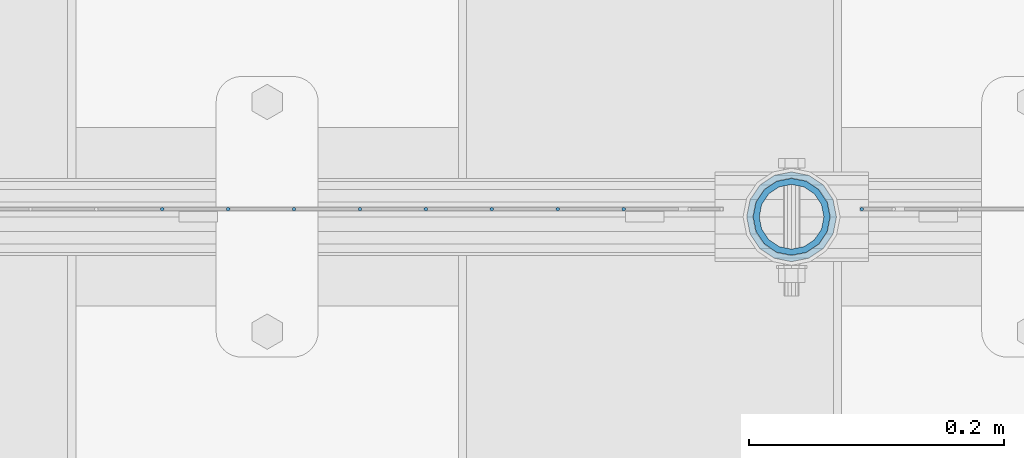
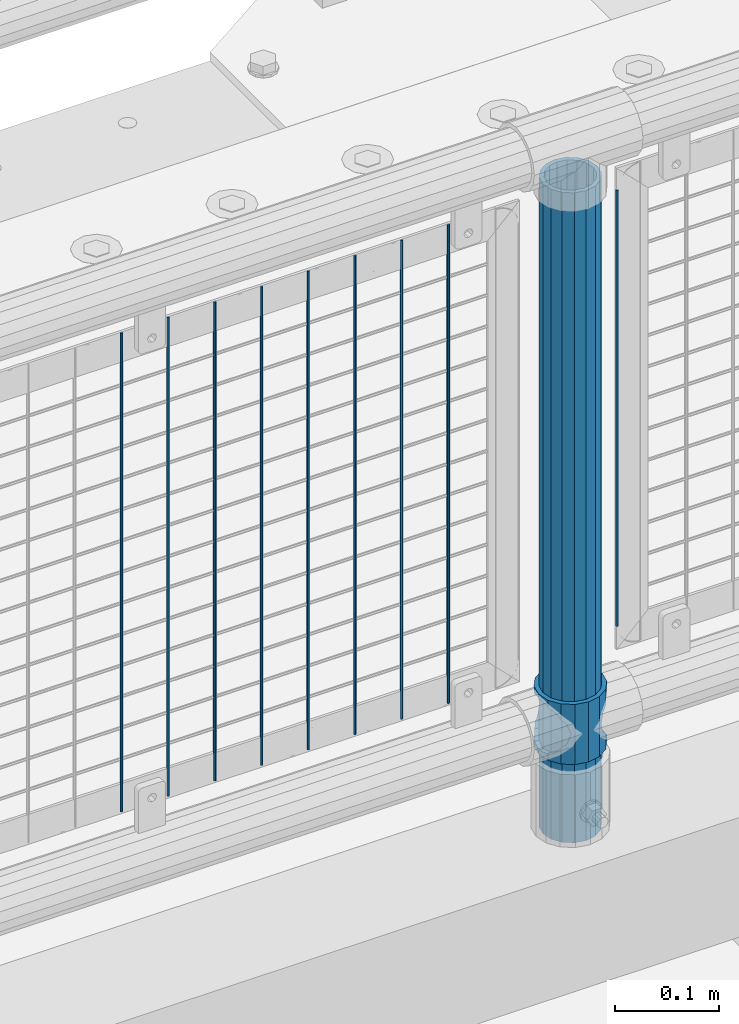
# One storey, part 85 of 240: 11 columns.
"""IFC2X3 building model written with IfcOpenShell, lengths in millimetres."""

from ifc_helpers import new_model, si_unit, frame, origin_with_axes, place, context, subcontext, project, spatial, faceted_brep, material, type_object, element, save


model = new_model("IFC2X3")

# Units and contexts
model_context = context("Model", 3, precision=1e-05, world=origin_with_axes())
body_context = subcontext(model_context, "Body", "Model", "MODEL_VIEW")
ifc_project = project(units=[si_unit("LENGTHUNIT", "METRE", prefix="MILLI"), si_unit("AREAUNIT", "SQUARE_METRE"), si_unit("VOLUMEUNIT", "CUBIC_METRE"), si_unit("MASSUNIT", "GRAM", prefix="KILO"), si_unit("TIMEUNIT", "SECOND"), si_unit("PLANEANGLEUNIT", "RADIAN"), si_unit("SOLIDANGLEUNIT", "STERADIAN"), si_unit("THERMODYNAMICTEMPERATUREUNIT", "DEGREE_CELSIUS"), si_unit("LUMINOUSINTENSITYUNIT", "LUMEN")], contexts=[model_context])

# Site, building, storey
site_placement = place(None, origin_with_axes())
site = spatial("IfcSite", under=ifc_project, at=site_placement, CompositionType="ELEMENT")
building_placement = place(site_placement, origin_with_axes())
building = spatial("IfcBuilding", under=site, at=building_placement, Name="Standard", CompositionType="ELEMENT")
storey_placement = place(building_placement, origin_with_axes())
storey = spatial("IfcBuildingStorey", under=building, at=storey_placement, Name="Undefined", CompositionType="ELEMENT", Elevation=0.0)

# Columns
ifc_material_1 = material(Name="Misc_Undefined")
column_type_1 = type_object("IfcColumnType", PredefinedType="NOTDEFINED")
column_1_placement = place(storey_placement, frame((51361.0, 34664.5, 263.02), z_axis=(-1.0, 0.0, 0.0), x_axis=(0.0, 0.0, 1.0)))
element("IfcColumn", 1, at=column_1_placement, inside=storey, type_object=column_type_1, material=ifc_material_1, context=body_context, shape_type="Brep", body=[
    faceted_brep([(56.6106908090114, 21.4606908090136, -21.4606908090136), (56.6106908090114, 21.4606908090136, -27.1226768591077), (61.9623795176703, 13.4513226476338, -32.4743655677739), (63.1897438117172, 11.6144421722784, -32.8397438117172), (63.1897438117172, 11.6144421722784, -28.0397438117143), (46.7644421722801, 28.0397438117143, -11.6144421722784), (46.7644421722801, 28.0397438117143, -20.0882031229849), (51.5310424079941, 24.8548033587067, -24.8548033587067), (35.1500000000015, 30.35, 0.0), (35.1499999999996, 30.3499999999985, -16.6306603983685), (23.5355578277192, 28.0397438117143, -11.6144421722784), (23.5355578277192, 28.0397438117143, -20.0882031229849), (13.6893091909879, 21.4606908090136, -21.4606908090136), (13.6893091909879, 21.4606908090136, -27.1226768591077), (18.7689575919921, 24.8548033587067, -24.8548033587067), (7.11025618828211, 11.6144421722784, -28.0397438117143), (7.11025618828211, 11.6144421722784, -32.8397438117172), (8.33762048232893, 13.4513226476338, -32.4743655677739), (4.79999999999961, 0.0, -30.3499999999985), (4.79999999999961, 0.0, -35.1500000000015), (7.11025618828211, -11.6144421722784, -28.0397438117143), (7.11025618828211, -11.6144421722784, -32.8397438117245), (13.6893091909879, -21.4606908090136, -21.4606908090136), (13.6893091909879, -21.4606908090136, -27.1226768591223), (8.33762048232455, -13.4513226476338, -32.4743655677739), (23.5355578277191, -28.0397438117143, -11.6144421722784), (23.5355578277191, -28.0397438117143, -20.0882031229994), (18.7689575919987, -24.8548033587067, -24.8548033587067), (35.1500000000015, -30.35, 0.0), (35.1499999999996, -30.3499999999985, -16.6306603983758), (46.7644421722801, -28.0397438117143, -11.6144421722784), (46.7644421722801, -28.0397438117143, -20.0882031229994), (56.6106908090114, -21.4606908090136, -21.4606908090136), (56.6106908090114, -21.4606908090136, -27.1226768591223), (51.5310424080006, -24.8548033587067, -24.8548033587067), (63.1897438117172, -11.6144421722784, -28.0397438117143), (63.1897438117172, -11.6144421722784, -32.8397438117245), (61.9623795176703, -13.4513226476338, -32.4743655677739), (65.4999999999997, 0.0, -30.3499999999985), (65.4999999999997, 0.0, -35.1500000000015), (0.0, -28.0397438117143, -11.6144421722784), (0.0, -30.3499999999985, 0.0), (0.0, -21.4606908090136, -21.4606908090136), (0.0, -11.6144421722784, -28.0397438117143), (0.0, 0.0, -30.3499999999985), (0.0, 11.6144421722784, -28.0397438117143), (0.0, 21.4606908090136, -21.4606908090136), (0.0, 28.0397438117143, -11.6144421722784), (0.0, 30.3499999999985, 0.0), (0.0, 28.0397438117143, 11.6144421722784), (23.5355578277192, 28.0397438117143, 11.6144421722784), (0.0, 21.4606908090136, 21.4606908090136), (13.6893091909879, 21.4606908090136, 21.4606908090136), (0.0, 11.6144421722784, 28.0397438117143), (7.11025618828211, 11.6144421722784, 28.0397438117143), (0.0, 0.0, 30.3499999999985), (4.79999999999961, 0.0, 30.3499999999985), (0.0, -11.6144421722784, 28.0397438117143), (7.11025618828205, -11.6144421722784, 28.0397438117143), (0.0, -21.4606908090136, 21.4606908090136), (13.6893091909879, -21.4606908090136, 21.4606908090136), (0.0, -28.0397438117143, 11.6144421722784), (23.5355578277191, -28.0397438117143, 11.6144421722784), (0.0, -32.4743655677739, 13.4513226476338), (0.0, -35.1500000000015, 0.0), (70.2999999999993, -35.1500000000015, 0.0), (70.2999999999993, -32.4743655677739, 13.4513226476338), (0.0, 13.4513226476338, -32.4743655677739), (0.0, 24.8548033587067, -24.8548033587067), (0.0, 0.0, -35.1500000000015), (0.0, -13.4513226476338, -32.4743655677739), (0.0, -24.8548033587067, -24.8548033587067), (0.0, -24.8548033587067, 24.8548033587067), (0.0, -13.4513226476338, 32.4743655677739), (0.0, 0.0, 35.1500000000015), (0.0, 13.4513226476338, 32.4743655677739), (0.0, 24.8548033587067, 24.8548033587067), (0.0, 32.4743655677739, 13.4513226476338), (0.0, 35.1500000000015, 0.0), (0.0, 32.4743655677739, -13.4513226476338), (0.0, -32.4743655677739, -13.4513226476338), (70.2999999999993, 32.4743655677739, 13.4513226476338), (70.2999999999993, 35.1500000000015, 0.0), (70.2999999999993, 32.4743655677739, -13.4513226476338), (70.2999999999993, 24.8548033587067, -24.8548033587067), (70.2999999999993, 13.4513226476338, -32.4743655677739), (70.2999999999993, 0.0, -35.1500000000015), (70.2999999999993, -13.4513226476338, -32.4743655677739), (70.2999999999993, -24.8548033587067, -24.8548033587067), (70.2999999999993, -32.4743655677739, -13.4513226476338), (70.2999999999993, 28.0397438117143, 11.6144421722784), (70.2999999999993, 21.4606908090136, 21.4606908090136), (56.6106908090114, 21.4606908090136, 21.4606908090136), (46.7644421722801, 28.0397438117143, 11.6144421722784), (70.2999999999993, 11.6144421722784, 28.0397438117143), (63.1897438117172, 11.6144421722784, 28.0397438117143), (70.2999999999993, 0.0, 30.3499999999985), (65.4999999999997, 0.0, 30.3499999999985), (70.2999999999993, -11.6144421722784, 28.0397438117143), (63.1897438117172, -11.6144421722784, 28.0397438117143), (70.2999999999993, -21.4606908090136, 21.4606908090136), (56.6106908090114, -21.4606908090136, 21.4606908090136), (70.2999999999993, -28.0397438117143, 11.6144421722784), (46.7644421722801, -28.0397438117143, 11.6144421722784), (70.2999999999993, -11.6144421722784, -28.0397438117143), (70.2999999999993, 0.0, -30.3499999999985), (70.2999999999993, -21.4606908090136, -21.4606908090136), (70.2999999999993, -28.0397438117143, -11.6144421722784), (70.2999999999993, -30.3499999999985, 0.0), (70.2999999999993, 24.8548033587067, 24.8548033587067), (70.2999999999993, 13.4513226476338, 32.4743655677739), (70.2999999999993, 0.0, 35.1500000000015), (70.2999999999993, -13.4513226476338, 32.4743655677739), (70.2999999999993, -24.8548033587067, 24.8548033587067), (70.2999999999993, 30.3499999999985, 0.0), (70.2999999999993, 28.0397438117143, -11.6144421722784), (70.2999999999993, 21.4606908090136, -21.4606908090136), (70.2999999999993, 11.6144421722784, -28.0397438117143), (61.9623795176742, 13.4513226476338, 32.4743655677739), (51.5310424079941, 24.8548033587067, 24.8548033587067), (56.6106908090114, 21.4606908090136, 27.1226768591077), (65.4999999999997, 0.0, 35.1500000000015), (63.1897438117172, 11.6144421722784, 32.8397438117172), (63.1897438117172, -11.6144421722784, 32.8397438117172), (61.9623795176698, -13.4513226476338, 32.4743655677739), (56.6106908090114, -21.4606908090136, 27.1226768591005), (51.5310424080006, -24.8548033587067, 24.8548033587067), (18.7689575919987, -24.8548033587067, 24.8548033587067), (46.7644421722801, -28.0397438117143, 20.0882031229994), (35.1499999999996, -30.3499999999985, 16.6306603983758), (23.5355578277191, -28.0397438117143, 20.0882031229994), (8.33762048232506, -13.4513226476338, 32.4743655677739), (13.6893091909879, -21.4606908090136, 27.1226768591005), (4.79999999999961, 0.0, 35.1500000000015), (7.11025618828205, -11.6144421722784, 32.8397438117172), (7.11025618828211, 11.6144421722784, 32.8397438117172), (8.33762048232506, 13.4513226476338, 32.4743655677739), (13.6893091909879, 21.4606908090136, 27.1226768591077), (18.7689575919856, 24.8548033587067, 24.8548033587067), (23.5355578277192, 28.0397438117143, 20.0882031229994), (35.1499999999996, 30.3499999999985, 16.6306603983758), (46.7644421722801, 28.0397438117143, 20.0882031229994)], [[[0, 1, 2, 3, 4]], [[5, 6, 7, 1, 0]], [[8, 9, 6, 5]], [[10, 11, 9, 8]], [[12, 13, 14, 11, 10]], [[15, 16, 17, 13, 12]], [[18, 19, 16, 15]], [[20, 21, 19, 18]], [[22, 23, 24, 21, 20]], [[25, 26, 27, 23, 22]], [[28, 29, 26, 25]], [[30, 31, 29, 28]], [[32, 33, 34, 31, 30]], [[35, 36, 37, 33, 32]], [[38, 39, 36, 35]], [[4, 3, 39, 38]], [[40, 41, 28, 25]], [[42, 40, 25, 22]], [[43, 42, 22, 20]], [[44, 43, 20, 18]], [[45, 44, 18, 15]], [[46, 45, 15, 12]], [[47, 46, 12, 10]], [[48, 47, 10, 8]], [[49, 48, 8, 50]], [[51, 49, 50, 52]], [[53, 51, 52, 54]], [[55, 53, 54, 56]], [[57, 55, 56, 58]], [[59, 57, 58, 60]], [[61, 59, 60, 62]], [[41, 61, 62, 28]], [[63, 64, 65, 66]], [[17, 67, 68, 14, 13]], [[19, 69, 67, 17, 16]], [[70, 69, 19, 21, 24]], [[71, 70, 24, 23, 27]], [[63, 72, 73, 74, 75, 76, 77, 78, 79, 68, 67, 69, 70, 71, 80, 64], [40, 42, 43, 44, 45, 46, 47, 48, 49, 51, 53, 55, 57, 59, 61, 41]], [[78, 77, 81, 82]], [[79, 78, 82, 83]], [[14, 68, 79, 83, 84, 7, 6, 9, 11]], [[84, 85, 2, 1, 7]], [[85, 86, 39, 3, 2]], [[37, 87, 88, 34, 33]], [[39, 86, 87, 37, 36]], [[34, 88, 89, 80, 71, 27, 26, 29, 31]], [[64, 80, 89, 65]], [[90, 91, 92, 93]], [[91, 94, 95, 92]], [[94, 96, 97, 95]], [[96, 98, 99, 97]], [[98, 100, 101, 99]], [[100, 102, 103, 101]], [[104, 105, 38, 35]], [[106, 104, 35, 32]], [[107, 106, 32, 30]], [[108, 107, 30, 28]], [[102, 108, 28, 103]], [[88, 87, 86, 85, 84, 83, 82, 81, 109, 110, 111, 112, 113, 66, 65, 89], [100, 98, 96, 94, 91, 90, 114, 115, 116, 117, 105, 104, 106, 107, 108, 102]], [[118, 110, 109, 119, 120]], [[121, 111, 110, 118, 122]], [[112, 111, 121, 123, 124]], [[113, 112, 124, 125, 126]], [[127, 72, 63, 66, 113, 126, 128, 129, 130]], [[131, 73, 72, 127, 132]], [[133, 74, 73, 131, 134]], [[75, 74, 133, 135, 136]], [[76, 75, 136, 137, 138]], [[119, 109, 81, 77, 76, 138, 139, 140, 141]], [[92, 120, 119, 141, 93]], [[95, 122, 118, 120, 92]], [[97, 121, 122, 95]], [[99, 123, 121, 97]], [[101, 125, 124, 123, 99]], [[103, 128, 126, 125, 101]], [[28, 129, 128, 103]], [[62, 130, 129, 28]], [[60, 132, 127, 130, 62]], [[58, 134, 131, 132, 60]], [[56, 133, 134, 58]], [[54, 135, 133, 56]], [[52, 137, 136, 135, 54]], [[50, 139, 138, 137, 52]], [[8, 140, 139, 50]], [[93, 141, 140, 8]], [[114, 90, 93, 8]], [[115, 114, 8, 5]], [[116, 115, 5, 0]], [[117, 116, 0, 4]], [[105, 117, 4, 38]]]),
])
ifc_material_2 = material()
column_type_2 = type_object("IfcColumnType", PredefinedType="NOTDEFINED")
column_2_placement = place(storey_placement, frame((51361.0, 34664.5, 168.02), z_axis=(-1.0, 0.0, 0.0), x_axis=(0.0, 0.0, 1.0)))
element("IfcColumn", 2, at=column_2_placement, inside=storey, type_object=column_type_2, material=ifc_material_2, context=body_context, shape_type="Brep", body=[
    faceted_brep([(0.0, -25.3499999999985, 0.0), (0.0, -23.4203461491634, 9.70102501045767), (760.0, -23.4203461491634, 9.70102501045767), (760.0, -25.3499999999985, 0.0), (0.0, -17.9251569030821, 17.9251569030821), (760.0, -17.9251569030821, 17.9251569030821), (0.0, -9.70102501045767, 23.4203461491634), (760.0, -9.70102501045767, 23.4203461491634), (0.0, 0.0, 25.3499999999985), (760.0, 0.0, 25.3499999999985), (0.0, 9.70102501045767, 23.4203461491634), (760.0, 9.70102501045767, 23.4203461491634), (0.0, 17.9251569030821, 17.9251569030821), (760.0, 17.9251569030821, 17.9251569030821), (0.0, 23.4203461491634, 9.70102501045767), (760.0, 23.4203461491634, 9.70102501045767), (0.0, 25.3499999999985, 0.0), (760.0, 25.3499999999985, 0.0), (0.0, 23.4203461491634, -9.70102501045767), (760.0, 23.4203461491634, -9.70102501045767), (0.0, 17.9251569030821, -17.9251569030821), (760.0, 17.9251569030821, -17.9251569030821), (0.0, 9.70102501045767, -23.4203461491634), (760.0, 9.70102501045767, -23.4203461491634), (0.0, 0.0, -25.3499999999985), (760.0, 0.0, -25.3499999999985), (0.0, -9.70102501045767, -23.4203461491634), (760.0, -9.70102501045767, -23.4203461491634), (0.0, -17.9251569030821, -17.9251569030821), (760.0, -17.9251569030821, -17.9251569030821), (0.0, -23.4203461491634, -9.70102501045767), (760.0, -23.4203461491634, -9.70102501045767), (0.0, -30.1500000000015, 0.0), (0.0, -27.8549679052157, -11.5379054858058), (760.0, -27.8549679052157, -11.5379054858058), (760.0, -30.1500000000015, 0.0), (0.0, -21.3192694527752, -21.3192694527752), (760.0, -21.3192694527752, -21.3192694527752), (0.0, -11.5379054858058, -27.8549679052157), (760.0, -11.5379054858058, -27.8549679052157), (0.0, 0.0, -30.1500000000015), (760.0, 0.0, -30.1500000000015), (0.0, 11.5379054858058, -27.8549679052157), (760.0, 11.5379054858058, -27.8549679052157), (0.0, 21.3192694527752, -21.3192694527752), (760.0, 21.3192694527752, -21.3192694527752), (0.0, 27.8549679052157, -11.5379054858058), (760.0, 27.8549679052157, -11.5379054858058), (0.0, 30.1500000000015, 0.0), (760.0, 30.1500000000015, 0.0), (0.0, 27.8549679052157, 11.5379054858058), (760.0, 27.8549679052157, 11.5379054858058), (0.0, 21.3192694527752, 21.3192694527752), (760.0, 21.3192694527752, 21.3192694527752), (0.0, 11.5379054858058, 27.8549679052157), (760.0, 11.5379054858058, 27.8549679052157), (0.0, 0.0, 30.1500000000015), (760.0, 0.0, 30.1500000000015), (0.0, -11.5379054858058, 27.8549679052157), (760.0, -11.5379054858058, 27.8549679052157), (0.0, -21.3192694527752, 21.3192694527752), (760.0, -21.3192694527752, 21.3192694527752), (0.0, -27.8549679052157, 11.5379054858058), (760.0, -27.8549679052157, 11.5379054858058)], [[[0, 1, 2, 3]], [[1, 4, 5, 2]], [[4, 6, 7, 5]], [[6, 8, 9, 7]], [[8, 10, 11, 9]], [[10, 12, 13, 11]], [[12, 14, 15, 13]], [[14, 16, 17, 15]], [[16, 18, 19, 17]], [[18, 20, 21, 19]], [[20, 22, 23, 21]], [[22, 24, 25, 23]], [[24, 26, 27, 25]], [[26, 28, 29, 27]], [[28, 30, 31, 29]], [[30, 0, 3, 31]], [[32, 33, 34, 35]], [[33, 36, 37, 34]], [[36, 38, 39, 37]], [[38, 40, 41, 39]], [[40, 42, 43, 41]], [[42, 44, 45, 43]], [[44, 46, 47, 45]], [[46, 48, 49, 47]], [[48, 50, 51, 49]], [[50, 52, 53, 51]], [[52, 54, 55, 53]], [[54, 56, 57, 55]], [[56, 58, 59, 57]], [[58, 60, 61, 59]], [[60, 62, 63, 61]], [[62, 32, 35, 63]], [[37, 39, 41, 43, 45, 47, 49, 51, 53, 55, 57, 59, 61, 63, 35, 34], [5, 7, 9, 11, 13, 15, 17, 19, 21, 23, 25, 27, 29, 31, 3, 2]], [[62, 60, 58, 56, 54, 52, 50, 48, 46, 44, 42, 40, 38, 36, 33, 32], [30, 28, 26, 24, 22, 20, 18, 16, 14, 12, 10, 8, 6, 4, 1, 0]]]),
])
column_type_3 = type_object("IfcColumnType", Name="D3", PredefinedType="NOTDEFINED")
column_3_placement = place(storey_placement, frame((51416.0, 34670.5, 378.020000000001), z_axis=(-1.0, 0.0, 0.0), x_axis=(0.0, 0.0, 1.0)))
element("IfcColumn", 3, at=column_3_placement, inside=storey, type_object=column_type_3, material=ifc_material_1, ObjectType="D3", context=body_context, shape_type="Brep", body=[
    faceted_brep([(-7.27595761418343e-12, -1.49999999999272, 0.0), (-7.27595761418343e-12, -0.749999999992724, -1.29903810567669), (510.0, -0.75, -1.29903810567339), (510.0, -1.5, 0.0), (0.0, 0.750000000007276, -1.29903810567669), (510.0, 0.75, -1.29903810567339), (0.0, 1.50000000000728, 0.0), (510.0, 1.5, 0.0), (0.0, 0.750000000007276, 1.29903810567669), (510.0, 0.75, 1.29903810567339), (-7.27595761418343e-12, -0.749999999992724, 1.29903810567669), (510.0, -0.75, 1.29903810567339)], [[[0, 1, 2, 3]], [[1, 4, 5, 2]], [[4, 6, 7, 5]], [[6, 8, 9, 7]], [[8, 10, 11, 9]], [[10, 0, 3, 11]], [[5, 7, 9, 11, 3, 2]], [[10, 8, 6, 4, 1, 0]]]),
])
for number, where, z_axis, x_axis in (
    (4, (51229.34, 34670.5, 353.020000000001), (-1.0, 0.0, 0.0), (0.0, 0.0, 1.0)),
    (5, (51177.685, 34670.5, 353.020000000001), (-1.0, 0.0, 0.0), (0.0, 0.0, 1.0)),
    (6, (51126.03, 34670.5, 353.020000000001), (-1.0, 0.0, 0.0), (0.0, 0.0, 1.0)),
    (7, (51074.375, 34670.5, 353.020000000001), (-1.0, 0.0, 0.0), (0.0, 0.0, 1.0)),
    (8, (51022.72, 34670.5, 353.020000000001), (-1.0, 0.0, 0.0), (0.0, 0.0, 1.0)),
    (9, (50971.065, 34670.5, 353.020000000001), (-1.0, 0.0, 0.0), (0.0, 0.0, 1.0)),
    (10, (50919.41, 34670.5, 353.020000000001), (-1.0, 0.0, 0.0), (0.0, 0.0, 1.0)),
    (11, (50867.755, 34670.5, 353.020000000001), (-1.0, 0.0, 0.0), (0.0, 0.0, 1.0)),
):
    element("IfcColumn", number, at=place(storey_placement, frame(where, z_axis=z_axis, x_axis=x_axis)), inside=storey, type_object=column_type_3, material=ifc_material_1, ObjectType="D3", context=body_context, shape_type="Brep", body=[
        faceted_brep([(-7.27595761418343e-12, -1.49999999999272, 0.0), (-7.27595761418343e-12, -0.749999999992724, -1.29903810567669), (560.0, -0.75, -1.29903810567339), (560.0, -1.5, 0.0), (0.0, 0.750000000007276, -1.29903810567669), (560.0, 0.75, -1.29903810567339), (0.0, 1.50000000000728, 0.0), (560.0, 1.5, 0.0), (0.0, 0.750000000007276, 1.29903810567669), (560.0, 0.75, 1.29903810567339), (-7.27595761418343e-12, -0.749999999992724, 1.29903810567669), (560.0, -0.75, 1.29903810567339)], [[[0, 1, 2, 3]], [[1, 4, 5, 2]], [[4, 6, 7, 5]], [[6, 8, 9, 7]], [[8, 10, 11, 9]], [[10, 0, 3, 11]], [[5, 7, 9, 11, 3, 2]], [[10, 8, 6, 4, 1, 0]]]),
    ])

save(model, "model.ifc")
